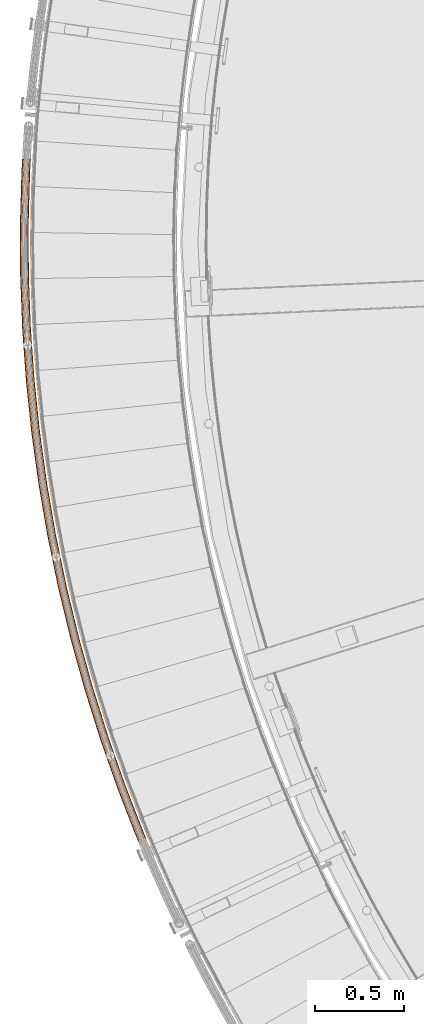
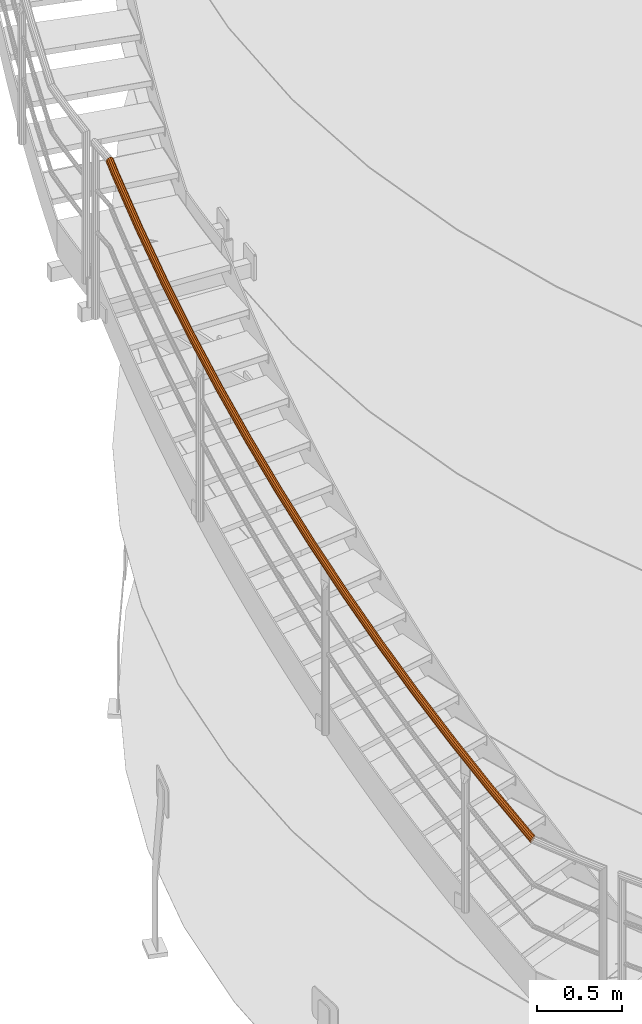
# One storey, part 11 of 126: 1 proxy.
"""IFC2X3 building model written with IfcOpenShell, lengths in millimetres."""

from ifc_helpers import new_model, si_unit, origin, origin_with_axes, place, context, project, spatial, faceted_brep, material, element, save


model = new_model("IFC2X3")

# Units and contexts
context_of_model_1 = context(None, 3, precision=0.1, world=origin())
context_of_model_2 = context(None, 3, precision=0.1, world=origin())
ifc_project = project(units=[si_unit("LENGTHUNIT", "METRE", prefix="MILLI"), si_unit("AREAUNIT", "SQUARE_METRE", prefix="CENTI"), si_unit("VOLUMEUNIT", "CUBIC_METRE", prefix="CENTI"), si_unit("MASSUNIT", "GRAM", prefix="KILO")], contexts=[context_of_model_1, context_of_model_2])

# Site, building, storey
site_placement = place(None, origin_with_axes())
site = spatial("IfcSite", under=ifc_project, at=site_placement, CompositionType="ELEMENT")
building_placement = place(site_placement, origin_with_axes())
building = spatial("IfcBuilding", under=site, at=building_placement, CompositionType="ELEMENT")
storey_placement = place(building_placement, origin_with_axes())
storey = spatial("IfcBuildingStorey", under=building, at=storey_placement, CompositionType="ELEMENT")

# Proxy
ifc_material = material(Name="S235JRG2")
proxy_placement = place(storey_placement, origin_with_axes())
element("IfcBuildingElementProxy", 1, at=proxy_placement, inside=storey, material=ifc_material, Name="HANDLAUF", context=context_of_model_2, shape_type="Brep", body=[
    faceted_brep([(-198.3403, 4647.0684, 3886.6389), (-210.2254, 4644.1455, 3884.089), (-200.9242, 4622.4582, 3867.4572), (-189.6834, 4626.8834, 3871.1592), (-220.3955, 4645.4326, 3876.9336), (-209.9616, 4621.104, 3858.2762), (-226.1257, 4650.5847, 3867.0899), (-214.3739, 4623.1835, 3846.0762), (-225.8803, 4658.2214, 3857.1956), (-212.979, 4628.1396, 3834.1262), (-219.7253, 4666.2963, 3849.9018), (-206.1505, 4634.6443, 3825.6282), (-209.3098, 4672.6459, 3847.163), (-195.7182, 4640.9546, 3822.8592), (-197.4247, 4675.5687, 3849.7128), (-184.4774, 4645.3798, 3826.5612), (-187.2546, 4674.2817, 3856.8683), (-175.44, 4646.734, 3835.7422), (-181.5245, 4669.1296, 3866.7119), (-171.0277, 4644.6545, 3847.9422), (-181.7698, 4661.4929, 3876.6062), (-172.4226, 4639.6984, 3859.8922), (-187.9248, 4653.4179, 3883.9), (-179.2511, 4633.1937, 3868.3902), (-198.908, 4648.3923, 3884.5956), (-189.5708, 4654.0845, 3882.1403), (-180.6434, 4633.2688, 3866.1769), (-189.9958, 4627.6117, 3868.6592), (-184.0529, 4661.3236, 3875.6015), (-174.5218, 4639.1001, 3858.5586), (-183.833, 4668.1697, 3866.7315), (-173.2713, 4643.5432, 3847.8456), (-188.9699, 4672.7884, 3857.9068), (-177.2269, 4645.4074, 3836.9086), (-198.0873, 4673.9423, 3851.4922), (-185.3287, 4644.1934, 3828.678), (-208.7421, 4671.322, 3849.2062), (-195.4059, 4640.2263, 3825.3592), (-218.0793, 4665.6297, 3851.6616), (-204.7582, 4634.5692, 3827.8415), (-223.5972, 4658.3907, 3858.2003), (-210.8798, 4628.7379, 3835.4598), (-223.8171, 4651.5446, 3867.0704), (-212.1303, 4624.2949, 3846.1727), (-218.6802, 4646.9258, 3875.895), (-208.1748, 4622.4306, 3857.1098), (-209.5628, 4645.772, 3882.3097), (-200.0729, 4623.6447, 3865.3404), (-305.4021, 4921.542, 4094.2856), (-317.3778, 4919.0158, 4091.7357), (-327.4994, 4920.6404, 4084.5801), (-333.0549, 4925.9802, 4074.7363), (-332.5558, 4933.6045, 4064.8421), (-326.136, 4941.4702, 4057.5485), (-315.5156, 4947.47, 4054.8097), (-303.5403, 4949.9961, 4057.3595), (-293.4187, 4948.3718, 4064.5148), (-287.8629, 4943.0323, 4074.3583), (-288.3616, 4935.408, 4084.2527), (-294.7814, 4927.542, 4091.5467), (-305.9255, 4922.884, 4092.2424), (-296.4043, 4928.2629, 4089.7869), (-290.6491, 4935.3146, 4083.2481), (-290.202, 4942.1496, 4074.378), (-295.1827, 4946.9365, 4065.5534), (-304.2565, 4948.3926, 4059.1388), (-314.9921, 4946.128, 4056.853), (-324.5131, 4940.7493, 4059.3083), (-330.2684, 4933.6978, 4065.8468), (-330.7158, 4926.8628, 4074.7168), (-325.7354, 4922.0757, 4083.5415), (-316.6615, 4920.6194, 4089.9564), (-403.2832, 5199.422, 4301.9324), (-415.3363, 5197.2952, 4299.3824), (-425.3984, 5199.2552, 4292.2268), (-430.7734, 5204.7767, 4282.3831), (-430.0212, 5212.3802, 4272.4888), (-423.3434, 5220.0283, 4265.1952), (-412.5295, 5225.6717, 4262.4565), (-400.4769, 5227.7985, 4265.0063), (-390.4149, 5225.8388, 4272.1615), (-385.0396, 5220.3175, 4282.0051), (-385.7914, 5212.714, 4291.8995), (-392.469, 5205.0657, 4299.1934), (-403.7618, 5200.7807, 4299.8891), (-394.0671, 5205.8402, 4297.4337), (-388.0807, 5212.6967, 4290.8948), (-387.4067, 5219.5131, 4282.0247), (-392.2256, 5224.4628, 4273.2001), (-401.246, 5226.2197, 4266.7856), (-412.0509, 5224.3131, 4264.4997), (-421.7454, 5219.2538, 4266.955), (-427.7318, 5212.3974, 4273.4936), (-428.4062, 5205.5811, 4282.3636), (-423.5876, 5200.6311, 4291.1883), (-414.5671, 5198.8741, 4297.6031), (-491.8757, 5480.4014, 4509.5791), (-503.9927, 5478.6763, 4507.0291), (-513.9841, 5480.9696, 4499.8736), (-519.1727, 5486.6667, 4490.0298), (-518.1682, 5494.2409, 4480.1356), (-511.24, 5501.6629, 4472.842), (-500.2445, 5506.9439, 4470.1032), (-488.1278, 5508.6689, 4472.653), (-478.1365, 5506.3759, 4479.8083), (-472.9477, 5500.679, 4489.6518), (-473.9518, 5493.1047, 4499.5462), (-480.8799, 5485.6826, 4506.8402), (-492.3088, 5481.7752, 4507.5359), (-482.4513, 5486.5097, 4505.0804), (-476.2404, 5493.1635, 4498.5416), (-475.3402, 5499.9537, 4489.6715), (-479.9919, 5505.0608, 4480.8469), (-488.9489, 5507.1165, 4474.4323), (-499.8113, 5505.57, 4472.1465), (-509.6686, 5500.8357, 4474.6017), (-515.8796, 5494.1821, 4481.1403), (-516.78, 5487.3919, 4490.0103), (-512.1286, 5482.2846, 4498.835), (-503.1715, 5480.2287, 4505.2499), (-571.0815, 5764.1697, 4717.2259), (-583.2492, 5762.8482, 4714.6759), (-593.1588, 5765.4723, 4707.5203), (-598.1552, 5771.3387, 4697.6765), (-596.8995, 5778.8754, 4687.7823), (-589.7285, 5786.063, 4680.4887), (-578.5636, 5790.9756, 4677.7499), (-566.3963, 5792.2971, 4680.2998), (-556.4867, 5789.6733, 4687.455), (-551.49, 5783.8071, 4697.2986), (-552.7453, 5776.2704, 4707.193), (-559.9163, 5769.0825, 4714.4869), (-571.4688, 5765.5571, 4715.1826), (-561.4594, 5769.9614, 4712.7272), (-555.0307, 5776.4052, 4706.1883), (-553.9054, 5783.1617, 4697.3182), (-558.3848, 5788.4206, 4688.4936), (-567.2686, 5790.7728, 4682.0791), (-578.1763, 5789.5882, 4679.7932), (-588.1855, 5785.184, 4682.2485), (-594.6141, 5778.7405, 4688.7871), (-595.7398, 5771.984, 4697.6571), (-591.2606, 5766.7249, 4706.4818), (-582.3768, 5764.3725, 4712.8966), (-640.8132, 6050.4135, 4924.8726), (-653.018, 6049.4971, 4922.3226), (-662.835, 6052.449, 4915.167), (-667.6337, 6058.4782, 4905.3233), (-666.1283, 6065.969, 4895.4291), (-658.7223, 6072.9144, 4888.1355), (-647.4003, 6077.4533, 4885.3967), (-635.1958, 6078.3696, 4887.9465), (-625.3789, 6075.4179, 4895.1018), (-620.5799, 6069.389, 4904.9453), (-622.085, 6061.8981, 4914.8397), (-629.4908, 6054.9526, 4922.1336), (-641.1541, 6051.813, 4922.8293), (-631.0039, 6055.8822, 4920.3739), (-624.3647, 6062.1088, 4913.8351), (-623.0154, 6068.8242, 4904.965), (-627.3176, 6074.229, 4896.1404), (-636.1183, 6076.8752, 4889.7258), (-647.0594, 6076.0537, 4887.44), (-657.2093, 6071.9846, 4889.8952), (-663.8486, 6065.7583, 4896.4338), (-665.1982, 6059.0429, 4905.3038), (-660.8963, 6053.6379, 4914.1285), (-652.0955, 6050.9915, 4920.5434), (-700.9937, 6338.8165, 5132.5194), (-713.2223, 6338.3063, 5129.9694), (-722.9358, 6341.5828, 5122.8138), (-727.5314, 6347.7681, 5112.97), (-725.7778, 6355.2048, 5103.0758), (-718.1452, 6361.9001, 5095.7822), (-706.6786, 6366.0603, 5093.0434), (-694.4504, 6366.5706, 5095.5933), (-684.737, 6363.2942, 5102.7485), (-680.1411, 6357.1091, 5112.5921), (-681.8942, 6349.6724, 5122.4864), (-689.5268, 6342.9768, 5129.7804), (-701.288, 6340.2266, 5130.4761), (-691.0081, 6343.9563, 5128.0207), (-684.1656, 6349.9587, 5121.4818), (-682.594, 6356.6256, 5112.6117), (-686.7141, 6362.1704, 5103.7871), (-695.422, 6365.1076, 5097.3726), (-706.3843, 6364.6501, 5095.0867), (-716.6639, 6360.9207, 5097.542), (-723.5065, 6354.9184, 5104.0806), (-725.0784, 6348.2516, 5112.9505), (-720.9586, 6342.7066, 5121.7753), (-712.2506, 6339.7692, 5128.1901), (-751.5566, 6629.0602, 5340.1661), (-763.7954, 6628.9566, 5337.6161), (-773.3946, 6632.5542, 5330.4605), (-777.7821, 6638.8888, 5320.6168), (-775.7824, 6646.2631, 5310.7226), (-767.9315, 6652.7011, 5303.429), (-756.333, 6656.4779, 5300.6902), (-744.0946, 6656.5815, 5303.24), (-734.4954, 6652.9842, 5310.3952), (-730.1076, 6646.6497, 5320.2388), (-732.1069, 6639.2754, 5330.1332), (-739.9577, 6632.8372, 5337.4271), (-751.8038, 6630.4793, 5338.1228), (-741.4057, 6633.8653, 5335.6674), (-734.3675, 6639.637, 5329.1286), (-732.5752, 6646.248, 5320.2584), (-736.5088, 6651.9267, 5311.4339), (-745.1142, 6655.1516, 5305.0193), (-756.0857, 6655.0587, 5302.7335), (-766.4836, 6651.6729, 5305.1887), (-773.5218, 6645.9014, 5311.7273), (-775.3145, 6639.2905, 5320.5973), (-771.3811, 6633.6116, 5329.422), (-762.7756, 6630.3865, 5335.8368), (-792.446, 6920.8239, 5547.8129), (-804.6815, 6921.1271, 5545.2629), (-814.1558, 6925.0417, 5538.1073), (-818.3304, 6931.5186, 5528.2635), (-816.0867, 6938.8224, 5518.3693), (-808.0262, 6944.9959, 5511.0757), (-796.3086, 6948.3852, 5508.3369), (-784.0735, 6948.082, 5510.8867), (-774.5992, 6944.1677, 5518.042), (-770.4243, 6937.6909, 5527.8856), (-772.6675, 6930.3871, 5537.7799), (-780.728, 6924.2133, 5545.0739), (-792.6459, 6922.2505, 5545.7696), (-782.141, 6925.289, 5543.3142), (-774.9149, 6930.8237, 5536.7753), (-772.9039, 6937.3714, 5527.9052), (-776.6466, 6943.1777, 5519.0806), (-785.1401, 6946.6868, 5512.6661), (-796.1086, 6946.9586, 5510.3802), (-806.6133, 6943.9202, 5512.8355), (-813.8394, 6938.3857, 5519.3741), (-815.8508, 6931.8381, 5528.244), (-812.1083, 6926.0316, 5537.0688), (-803.6148, 6922.5223, 5543.4836), (-823.6167, 7213.7854, 5755.4596), (-835.8354, 7214.495, 5752.9096), (-845.1744, 7218.7223, 5745.754), (-849.1314, 7225.3344, 5735.9103), (-846.6463, 7232.5595, 5726.0161), (-838.385, 7238.4618, 5718.7225), (-826.5612, 7241.4597, 5715.9837), (-814.343, 7240.7502, 5718.5335), (-805.004, 7236.5231, 5725.6887), (-801.0466, 7229.9112, 5735.5323), (-803.5314, 7222.686, 5745.4267), (-811.7926, 7216.7835, 5752.7206), (-823.7691, 7215.2178, 5753.4163), (-813.1691, 7217.9055, 5750.9609), (-805.763, 7223.197, 5744.4221), (-803.5355, 7229.6743, 5735.5519), (-807.0832, 7235.6017, 5726.7274), (-815.4554, 7239.3912, 5720.3128), (-826.4088, 7240.0273, 5718.0269), (-837.0086, 7237.3397, 5720.4822), (-844.4147, 7232.0484, 5727.0208), (-846.6426, 7225.5712, 5735.8908), (-843.0951, 7219.6436, 5744.7155), (-834.7229, 7215.854, 5751.1303), (-845.0344, 7507.6208, 5963.1063), (-857.2227, 7508.7362, 5960.5564), (-866.4161, 7513.2715, 5953.4008), (-870.1512, 7520.0114, 5943.557), (-867.4273, 7527.15, 5933.6628), (-858.9744, 7532.7744, 5926.3692), (-847.0575, 7535.3778, 5923.6304), (-834.8696, 7534.2626, 5926.1802), (-825.6763, 7529.7275, 5933.3355), (-821.9408, 7522.9877, 5943.1791), (-824.6643, 7515.8491, 5953.0734), (-833.1171, 7510.2244, 5960.3674), (-845.1391, 7509.0575, 5961.0631), (-834.4555, 7511.3915, 5958.6077), (-826.8777, 7516.434, 5952.0688), (-824.4362, 7522.8336, 5943.1987), (-827.7849, 7528.8757, 5934.3741), (-836.0266, 7532.9413, 5927.9596), (-846.9528, 7533.9411, 5925.6737), (-857.6361, 7531.6072, 5928.129), (-865.2139, 7526.565, 5934.6676), (-867.6558, 7520.1654, 5943.5375), (-864.3073, 7514.1232, 5952.3623), (-856.0656, 7510.0574, 5958.7771), (-856.6752, 7802.0058, 6170.7531), (-868.8197, 7803.5256, 6168.2031), (-877.8573, 7808.3639, 6161.0475), (-881.3664, 7815.2242, 6151.2038), (-878.4068, 7822.2683, 6141.3096), (-869.7717, 7827.6088, 6134.016), (-857.7749, 7829.8147, 6131.2772), (-845.6307, 7828.295, 6133.827), (-836.5932, 7823.4569, 6140.9822), (-833.0838, 7816.5967, 6150.8258), (-836.043, 7809.5525, 6160.7202), (-844.6781, 7804.2118, 6168.0141), (-856.7322, 7803.4452, 6168.7098), (-845.9769, 7805.4228, 6166.2544), (-838.2358, 7810.2107, 6159.7155), (-835.5828, 7816.5256, 6150.8454), (-838.7289, 7822.6757, 6142.0209), (-846.831, 7827.0129, 6135.6063), (-857.7179, 7828.3753, 6133.3204), (-868.4729, 7826.3977, 6135.7757), (-876.2141, 7821.6101, 6142.3143), (-878.8673, 7815.2952, 6151.1843), (-875.7215, 7809.1451, 6160.009), (-867.6194, 7804.8076, 6166.4238), (-858.5265, 8096.615, 6378.3998), (-870.6138, 8098.5375, 6375.8499), (-879.4856, 8103.6735, 6368.6943), (-882.7647, 8110.6467, 6358.8505), (-879.5727, 8117.5885, 6348.9563), (-870.7648, 8122.6391, 6341.6627), (-858.7013, 8124.4451, 6338.9239), (-846.6144, 8122.5227, 6341.4737), (-837.7426, 8117.3869, 6348.629), (-834.4631, 8110.4139, 6358.4725), (-837.6548, 8103.4719, 6368.3669), (-846.4626, 8098.4211, 6375.6609), (-858.5355, 8098.0555, 6376.3566), (-847.7205, 8099.6746, 6373.9011), (-839.8245, 8104.2025, 6367.3623), (-836.9632, 8110.4259, 6358.4922), (-839.9032, 8116.6771, 6349.6676), (-847.8566, 8121.2812, 6343.253), (-858.6923, 8123.0046, 6340.9672), (-869.507, 8121.3855, 6343.4225), (-877.403, 8116.8578, 6349.961), (-880.2646, 8110.6346, 6358.831), (-877.3249, 8104.3833, 6367.6557), (-869.3715, 8099.779, 6374.0706), (-850.5861, 8391.123, 6586.0466), (-862.6028, 8393.4462, 6583.4966), (-871.299, 8398.8741, 6576.341), (-874.3446, 8405.9524, 6566.4973), (-870.9236, 8412.7844, 6556.6031), (-861.9528, 8417.5394, 6549.3095), (-849.836, 8418.9435, 6546.5707), (-837.8196, 8416.6205, 6549.1205), (-829.1234, 8411.1927, 6556.2757), (-826.0774, 8404.1146, 6566.1193), (-829.4981, 8397.2825, 6576.0137), (-838.4688, 8392.5272, 6583.3076), (-850.5472, 8392.563, 6584.0033), (-839.6844, 8393.8218, 6581.5479), (-831.6423, 8398.0848, 6575.009), (-828.5757, 8404.2096, 6566.1389), (-831.3064, 8410.5551, 6557.3144), (-839.1023, 8415.421, 6550.8998), (-849.8748, 8417.5035, 6548.6139), (-860.7373, 8416.2448, 6551.0692), (-868.7795, 8411.982, 6557.6078), (-871.8463, 8405.8573, 6566.4778), (-869.116, 8399.5117, 6575.3025), (-861.32, 8394.6457, 6581.7173), (-845.7556, 8471.2746, 6642.6405), (-857.7814, 8473.1789, 6639.7187), (-866.5532, 8476.6236, 6631.1114), (-869.7244, 8480.6858, 6619.1256), (-866.4473, 8484.278, 6606.97), (-857.5987, 8486.4388, 6597.8984), (-845.546, 8486.5891, 6594.3408), (-833.5165, 8484.6874, 6597.2533), (-824.7349, 8481.2425, 6605.859), (-821.5577, 8477.1774, 6617.8525), (-824.8385, 8473.5825, 6630.0173), (-833.6969, 8471.422, 6639.0906), (-845.7428, 8472.0672, 6640.1405), (-834.9327, 8472.1994, 6636.9577), (-826.9918, 8474.1362, 6628.8238), (-824.0508, 8477.3589, 6617.9186), (-826.8988, 8481.003, 6607.1671), (-834.7709, 8484.0913, 6599.4522), (-845.555, 8485.7962, 6596.8407), (-856.3602, 8485.6617, 6600.0297), (-864.2933, 8483.7246, 6608.1623), (-867.2313, 8480.5041, 6619.06), (-864.3881, 8476.8623, 6629.8054), (-856.5239, 8473.7742, 6637.5216)], [[[0, 1, 2, 3]], [[1, 4, 5, 2]], [[4, 6, 7, 5]], [[6, 8, 9, 7]], [[8, 10, 11, 9]], [[10, 12, 13, 11]], [[12, 14, 15, 13]], [[14, 16, 17, 15]], [[16, 18, 19, 17]], [[18, 20, 21, 19]], [[20, 22, 23, 21]], [[0, 3, 23, 22]], [[24, 25, 26, 27]], [[25, 28, 29, 26]], [[28, 30, 31, 29]], [[30, 32, 33, 31]], [[32, 34, 35, 33]], [[34, 36, 37, 35]], [[36, 38, 39, 37]], [[38, 40, 41, 39]], [[40, 42, 43, 41]], [[42, 44, 45, 43]], [[44, 46, 47, 45]], [[24, 27, 47, 46]], [[0, 48, 49, 1]], [[1, 49, 50, 4]], [[4, 50, 51, 6]], [[6, 51, 52, 8]], [[8, 52, 53, 10]], [[10, 53, 54, 12]], [[12, 54, 55, 14]], [[14, 55, 56, 16]], [[16, 56, 57, 18]], [[18, 57, 58, 20]], [[20, 58, 59, 22]], [[22, 59, 48, 0]], [[24, 60, 61, 25]], [[25, 61, 62, 28]], [[28, 62, 63, 30]], [[30, 63, 64, 32]], [[32, 64, 65, 34]], [[34, 65, 66, 36]], [[36, 66, 67, 38]], [[38, 67, 68, 40]], [[40, 68, 69, 42]], [[42, 69, 70, 44]], [[44, 70, 71, 46]], [[46, 71, 60, 24]], [[48, 72, 73, 49]], [[49, 73, 74, 50]], [[50, 74, 75, 51]], [[51, 75, 76, 52]], [[52, 76, 77, 53]], [[53, 77, 78, 54]], [[54, 78, 79, 55]], [[55, 79, 80, 56]], [[56, 80, 81, 57]], [[57, 81, 82, 58]], [[58, 82, 83, 59]], [[59, 83, 72, 48]], [[60, 84, 85, 61]], [[61, 85, 86, 62]], [[62, 86, 87, 63]], [[63, 87, 88, 64]], [[64, 88, 89, 65]], [[65, 89, 90, 66]], [[66, 90, 91, 67]], [[67, 91, 92, 68]], [[68, 92, 93, 69]], [[69, 93, 94, 70]], [[70, 94, 95, 71]], [[71, 95, 84, 60]], [[72, 96, 97, 73]], [[73, 97, 98, 74]], [[74, 98, 99, 75]], [[75, 99, 100, 76]], [[76, 100, 101, 77]], [[77, 101, 102, 78]], [[78, 102, 103, 79]], [[79, 103, 104, 80]], [[80, 104, 105, 81]], [[81, 105, 106, 82]], [[82, 106, 107, 83]], [[83, 107, 96, 72]], [[84, 108, 109, 85]], [[85, 109, 110, 86]], [[86, 110, 111, 87]], [[87, 111, 112, 88]], [[88, 112, 113, 89]], [[89, 113, 114, 90]], [[90, 114, 115, 91]], [[91, 115, 116, 92]], [[92, 116, 117, 93]], [[93, 117, 118, 94]], [[94, 118, 119, 95]], [[95, 119, 108, 84]], [[96, 120, 121, 97]], [[97, 121, 122, 98]], [[98, 122, 123, 99]], [[99, 123, 124, 100]], [[100, 124, 125, 101]], [[101, 125, 126, 102]], [[102, 126, 127, 103]], [[103, 127, 128, 104]], [[104, 128, 129, 105]], [[105, 129, 130, 106]], [[106, 130, 131, 107]], [[107, 131, 120, 96]], [[108, 132, 133, 109]], [[109, 133, 134, 110]], [[110, 134, 135, 111]], [[111, 135, 136, 112]], [[112, 136, 137, 113]], [[113, 137, 138, 114]], [[114, 138, 139, 115]], [[115, 139, 140, 116]], [[116, 140, 141, 117]], [[117, 141, 142, 118]], [[118, 142, 143, 119]], [[119, 143, 132, 108]], [[120, 144, 145, 121]], [[121, 145, 146, 122]], [[122, 146, 147, 123]], [[123, 147, 148, 124]], [[124, 148, 149, 125]], [[125, 149, 150, 126]], [[126, 150, 151, 127]], [[127, 151, 152, 128]], [[128, 152, 153, 129]], [[129, 153, 154, 130]], [[130, 154, 155, 131]], [[131, 155, 144, 120]], [[132, 156, 157, 133]], [[133, 157, 158, 134]], [[134, 158, 159, 135]], [[135, 159, 160, 136]], [[136, 160, 161, 137]], [[137, 161, 162, 138]], [[138, 162, 163, 139]], [[139, 163, 164, 140]], [[140, 164, 165, 141]], [[141, 165, 166, 142]], [[142, 166, 167, 143]], [[143, 167, 156, 132]], [[144, 168, 169, 145]], [[145, 169, 170, 146]], [[146, 170, 171, 147]], [[147, 171, 172, 148]], [[148, 172, 173, 149]], [[149, 173, 174, 150]], [[150, 174, 175, 151]], [[151, 175, 176, 152]], [[152, 176, 177, 153]], [[153, 177, 178, 154]], [[154, 178, 179, 155]], [[155, 179, 168, 144]], [[156, 180, 181, 157]], [[157, 181, 182, 158]], [[158, 182, 183, 159]], [[159, 183, 184, 160]], [[160, 184, 185, 161]], [[161, 185, 186, 162]], [[162, 186, 187, 163]], [[163, 187, 188, 164]], [[164, 188, 189, 165]], [[165, 189, 190, 166]], [[166, 190, 191, 167]], [[167, 191, 180, 156]], [[168, 192, 193, 169]], [[169, 193, 194, 170]], [[170, 194, 195, 171]], [[171, 195, 196, 172]], [[172, 196, 197, 173]], [[173, 197, 198, 174]], [[174, 198, 199, 175]], [[175, 199, 200, 176]], [[176, 200, 201, 177]], [[177, 201, 202, 178]], [[178, 202, 203, 179]], [[179, 203, 192, 168]], [[180, 204, 205, 181]], [[181, 205, 206, 182]], [[182, 206, 207, 183]], [[183, 207, 208, 184]], [[184, 208, 209, 185]], [[185, 209, 210, 186]], [[186, 210, 211, 187]], [[187, 211, 212, 188]], [[188, 212, 213, 189]], [[189, 213, 214, 190]], [[190, 214, 215, 191]], [[191, 215, 204, 180]], [[192, 216, 217, 193]], [[193, 217, 218, 194]], [[194, 218, 219, 195]], [[195, 219, 220, 196]], [[196, 220, 221, 197]], [[197, 221, 222, 198]], [[198, 222, 223, 199]], [[199, 223, 224, 200]], [[200, 224, 225, 201]], [[201, 225, 226, 202]], [[202, 226, 227, 203]], [[203, 227, 216, 192]], [[204, 228, 229, 205]], [[205, 229, 230, 206]], [[206, 230, 231, 207]], [[207, 231, 232, 208]], [[208, 232, 233, 209]], [[209, 233, 234, 210]], [[210, 234, 235, 211]], [[211, 235, 236, 212]], [[212, 236, 237, 213]], [[213, 237, 238, 214]], [[214, 238, 239, 215]], [[215, 239, 228, 204]], [[216, 240, 241, 217]], [[217, 241, 242, 218]], [[218, 242, 243, 219]], [[219, 243, 244, 220]], [[220, 244, 245, 221]], [[221, 245, 246, 222]], [[222, 246, 247, 223]], [[223, 247, 248, 224]], [[224, 248, 249, 225]], [[225, 249, 250, 226]], [[226, 250, 251, 227]], [[227, 251, 240, 216]], [[228, 252, 253, 229]], [[229, 253, 254, 230]], [[230, 254, 255, 231]], [[231, 255, 256, 232]], [[232, 256, 257, 233]], [[233, 257, 258, 234]], [[234, 258, 259, 235]], [[235, 259, 260, 236]], [[236, 260, 261, 237]], [[237, 261, 262, 238]], [[238, 262, 263, 239]], [[239, 263, 252, 228]], [[240, 264, 265, 241]], [[241, 265, 266, 242]], [[242, 266, 267, 243]], [[243, 267, 268, 244]], [[244, 268, 269, 245]], [[245, 269, 270, 246]], [[246, 270, 271, 247]], [[247, 271, 272, 248]], [[248, 272, 273, 249]], [[249, 273, 274, 250]], [[250, 274, 275, 251]], [[251, 275, 264, 240]], [[252, 276, 277, 253]], [[253, 277, 278, 254]], [[254, 278, 279, 255]], [[255, 279, 280, 256]], [[256, 280, 281, 257]], [[257, 281, 282, 258]], [[258, 282, 283, 259]], [[259, 283, 284, 260]], [[260, 284, 285, 261]], [[261, 285, 286, 262]], [[262, 286, 287, 263]], [[263, 287, 276, 252]], [[264, 288, 289, 265]], [[265, 289, 290, 266]], [[266, 290, 291, 267]], [[267, 291, 292, 268]], [[268, 292, 293, 269]], [[269, 293, 294, 270]], [[270, 294, 295, 271]], [[271, 295, 296, 272]], [[272, 296, 297, 273]], [[273, 297, 298, 274]], [[274, 298, 299, 275]], [[275, 299, 288, 264]], [[276, 300, 301, 277]], [[277, 301, 302, 278]], [[278, 302, 303, 279]], [[279, 303, 304, 280]], [[280, 304, 305, 281]], [[281, 305, 306, 282]], [[282, 306, 307, 283]], [[283, 307, 308, 284]], [[284, 308, 309, 285]], [[285, 309, 310, 286]], [[286, 310, 311, 287]], [[287, 311, 300, 276]], [[288, 312, 313, 289]], [[289, 313, 314, 290]], [[290, 314, 315, 291]], [[291, 315, 316, 292]], [[292, 316, 317, 293]], [[293, 317, 318, 294]], [[294, 318, 319, 295]], [[295, 319, 320, 296]], [[296, 320, 321, 297]], [[297, 321, 322, 298]], [[298, 322, 323, 299]], [[299, 323, 312, 288]], [[300, 324, 325, 301]], [[301, 325, 326, 302]], [[302, 326, 327, 303]], [[303, 327, 328, 304]], [[304, 328, 329, 305]], [[305, 329, 330, 306]], [[306, 330, 331, 307]], [[307, 331, 332, 308]], [[308, 332, 333, 309]], [[309, 333, 334, 310]], [[310, 334, 335, 311]], [[311, 335, 324, 300]], [[312, 336, 337, 313]], [[313, 337, 338, 314]], [[314, 338, 339, 315]], [[315, 339, 340, 316]], [[316, 340, 341, 317]], [[317, 341, 342, 318]], [[318, 342, 343, 319]], [[319, 343, 344, 320]], [[320, 344, 345, 321]], [[321, 345, 346, 322]], [[322, 346, 347, 323]], [[323, 347, 336, 312]], [[324, 348, 349, 325]], [[325, 349, 350, 326]], [[326, 350, 351, 327]], [[327, 351, 352, 328]], [[328, 352, 353, 329]], [[329, 353, 354, 330]], [[330, 354, 355, 331]], [[331, 355, 356, 332]], [[332, 356, 357, 333]], [[333, 357, 358, 334]], [[334, 358, 359, 335]], [[335, 359, 348, 324]], [[336, 360, 361, 337]], [[337, 361, 362, 338]], [[338, 362, 363, 339]], [[339, 363, 364, 340]], [[340, 364, 365, 341]], [[341, 365, 366, 342]], [[342, 366, 367, 343]], [[343, 367, 368, 344]], [[344, 368, 369, 345]], [[345, 369, 370, 346]], [[346, 370, 371, 347]], [[336, 347, 371, 360]], [[348, 372, 373, 349]], [[349, 373, 374, 350]], [[350, 374, 375, 351]], [[351, 375, 376, 352]], [[352, 376, 377, 353]], [[353, 377, 378, 354]], [[354, 378, 379, 355]], [[355, 379, 380, 356]], [[356, 380, 381, 357]], [[357, 381, 382, 358]], [[358, 382, 383, 359]], [[348, 359, 383, 372]], [[7, 9, 11, 13, 15, 17, 19, 21, 23, 3, 2, 5], [26, 29, 31, 33, 35, 37, 39, 41, 43, 45, 47, 27]], [[360, 371, 370, 369, 368, 367, 366, 365, 364, 363, 362, 361], [372, 383, 382, 381, 380, 379, 378, 377, 376, 375, 374, 373]]]),
])

save(model, "model.ifc")
